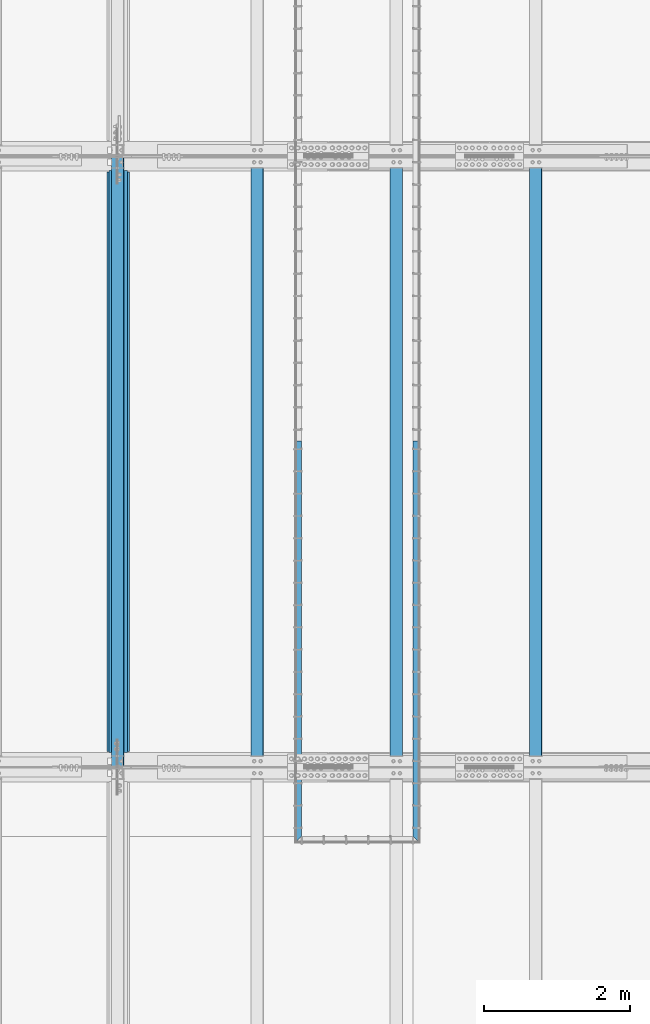
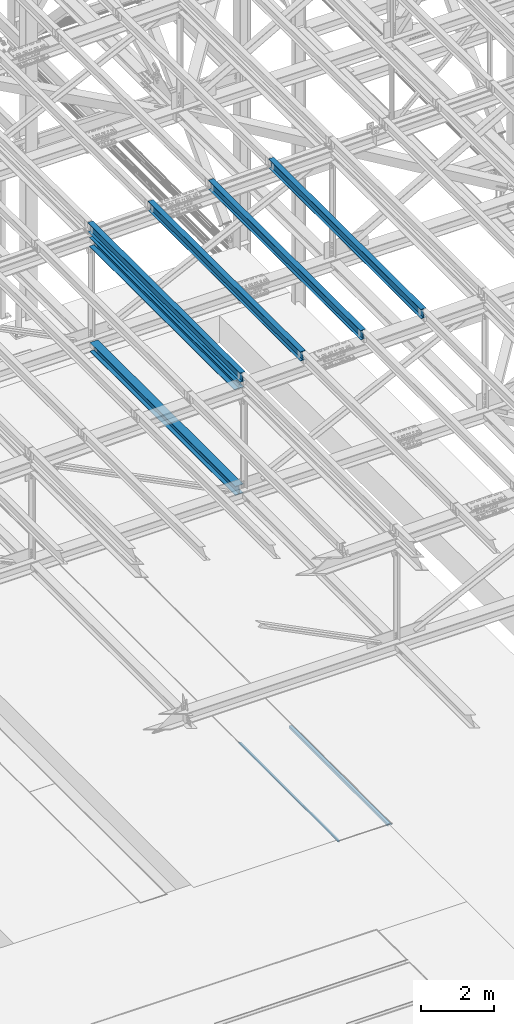
# One storey, part 1899 of 3843: 8 beams, 8 elements without a shape of their own.
"""IFC2X3 building model written with IfcOpenShell, lengths in millimetres."""

from ifc_helpers import new_model, si_unit, frame, origin_with_axes, place, context, subcontext, project, spatial, faceted_brep, material, type_object, element, aggregate, save


model = new_model("IFC2X3")

# Units and contexts
model_context = context("Model", 3, precision=1e-05, world=origin_with_axes())
body_context = subcontext(model_context, "Body", "Model", "MODEL_VIEW")
ifc_project = project(units=[si_unit("LENGTHUNIT", "METRE", prefix="MILLI"), si_unit("AREAUNIT", "SQUARE_METRE"), si_unit("VOLUMEUNIT", "CUBIC_METRE"), si_unit("MASSUNIT", "GRAM", prefix="KILO"), si_unit("TIMEUNIT", "SECOND"), si_unit("PLANEANGLEUNIT", "RADIAN"), si_unit("SOLIDANGLEUNIT", "STERADIAN"), si_unit("THERMODYNAMICTEMPERATUREUNIT", "DEGREE_CELSIUS"), si_unit("LUMINOUSINTENSITYUNIT", "LUMEN")], contexts=[model_context])

# Site, building, storey
site_placement = place(None, origin_with_axes())
site = spatial("IfcSite", under=ifc_project, at=site_placement, CompositionType="ELEMENT")
building_placement = place(site_placement, origin_with_axes())
building = spatial("IfcBuilding", under=site, at=building_placement, Name="Undefined", CompositionType="ELEMENT")
storey_placement = place(building_placement, origin_with_axes())
storey = spatial("IfcBuildingStorey", under=building, at=storey_placement, Name="Undefined", CompositionType="ELEMENT", Elevation=0.0)

# Assembly, beam
assembly_1_placement = place(storey_placement, origin_with_axes())
assembly_1 = element("IfcElementAssembly", 1, at=assembly_1_placement, inside=storey, Name="EMBED_ANGLE", AssemblyPlace="NOTDEFINED", PredefinedType="RIGID_FRAME")
ifc_material_1 = material(Name="STEEL/A36")
beam_type_1 = type_object("IfcBeamType", Name="L3-1/2X3-1/2X5/16", PredefinedType="NOTDEFINED")
beam_1_placement = place(assembly_1_placement, frame((66713.862, 71735.8227029324, 30410.15), z_axis=(0.0, 0.0, -1.0), x_axis=(0.0, -1.0, 0.0)))
beam_1 = element("IfcBeam", 2, at=beam_1_placement, type_object=beam_type_1, material=ifc_material_1, Name="EMBED_ANGLE", ObjectType="L3-1/2X3-1/2X5/16", context=body_context, shape_type="Brep", body=[
    faceted_brep([(-3.63797880709171e-12, 44.4499999999971, -44.4500000000007), (-3.63797880709171e-12, 44.4499999999971, 44.4500000000007), (5409.94572406872, 44.4500000096014, 44.4500000000007), (5409.94572406872, 44.4500000096014, -44.4500000000007), (-3.63797880709171e-12, 36.5124999999971, 44.4500000000007), (5417.88322413992, 36.5125000096305, 44.4500000000007), (-3.63797880709171e-12, 36.5124999999971, -36.5125000000007), (5417.88322413992, 36.5125000096305, -36.5125000000007), (3.63797880709171e-12, -44.4499999999971, -36.5125000000007), (5498.84572486606, -44.4499999902328, -36.5125000000007), (3.63797880709171e-12, -44.4499999999971, -44.4500000000007), (5498.84572486606, -44.4499999902328, -44.4500000000007)], [[[0, 1, 2, 3]], [[1, 4, 5, 2]], [[4, 6, 7, 5]], [[6, 8, 9, 7]], [[8, 10, 11, 9]], [[10, 0, 3, 11]], [[5, 7, 9, 11, 3, 2]], [[10, 8, 6, 4, 1, 0]]]),
])
aggregate(assembly_1, [beam_1])

assembly_2_placement = place(storey_placement, origin_with_axes())
assembly_2 = element("IfcElementAssembly", 3, at=assembly_2_placement, inside=storey, Name="EMBED_ANGLE", AssemblyPlace="NOTDEFINED", PredefinedType="RIGID_FRAME")
beam_2_placement = place(assembly_2_placement, frame((65101.0255318387, 66236.9770354062, 30410.15), z_axis=(0.0, 0.0, -1.0), x_axis=(0.0, 1.0, 0.0)))
beam_2 = element("IfcBeam", 4, at=beam_2_placement, type_object=beam_type_1, material=ifc_material_1, Name="EMBED_ANGLE", ObjectType="L3-1/2X3-1/2X5/16", context=body_context, shape_type="Brep", body=[
    faceted_brep([(88.8999999971129, 44.4500000000007, -44.4499999999971), (88.8999999965163, 44.4499999999971, 44.4500000000007), (5498.84566791133, 44.450000009776, 44.4500000000007), (5498.84566791133, 44.450000009776, -44.4500000000007), (80.9624999965163, 36.5124999999971, 44.4500000000007), (5498.84566791134, 36.512500009776, 44.4500000000007), (80.9624999971129, 36.5125000000007, -36.5124999999971), (5498.84566791134, 36.512500009776, -36.5125000000007), (3.63797880709171e-12, -44.4499999999971, -36.5125000000007), (5498.84566791149, -44.4499999902255, -36.5125000000007), (3.63797880709171e-12, -44.4499999999971, -44.4500000000007), (5498.84566791149, -44.4499999902255, -44.4500000000007)], [[[0, 1, 2, 3]], [[1, 4, 5, 2]], [[4, 6, 7, 5]], [[6, 8, 9, 7]], [[8, 10, 11, 9]], [[10, 0, 3, 11]], [[5, 7, 9, 11, 3, 2]], [[10, 8, 6, 4, 1, 0]]]),
])
aggregate(assembly_2, [beam_2])

assembly_3_placement = place(storey_placement, origin_with_axes())
assembly_3 = element("IfcElementAssembly", 5, at=assembly_3_placement, inside=storey, Name="BEAM", AssemblyPlace="NOTDEFINED", PredefinedType="RIGID_FRAME")
ifc_material_2 = material(Name="STEEL/A992")
beam_type_2 = type_object("IfcBeamType", Name="W12X26", PredefinedType="NOTDEFINED")
beam_3_placement = place(assembly_3_placement, frame((62633.1092623556, 67272.191026649, 46219.7494043175), z_axis=(-0.0211520980329588, 0.00187065200053622, 0.999774519284172), x_axis=(0.0, 0.999998249546997, -0.00187106999915266)))
beam_3 = element("IfcBeam", 6, at=beam_3_placement, type_object=beam_type_2, material=ifc_material_2, Name="BEAM", ObjectType="W12X26", context=body_context, shape_type="Brep", body=[
    faceted_brep([(12.7032892629941, 82.5499999995154, -155.575000000528), (12.6854712773056, 82.54999999953, -146.050000000505), (8343.90005472896, 82.5500000000902, -146.050000027339), (8343.91787271465, 82.5500000000757, -155.575000027362), (12.682329843461, 3.17499999966094, -146.050000000447), (8343.89691329512, 3.17500000022847, -146.05000002728), (12.1359116159729, 3.17500000032305, 146.050000000367), (8343.35049506764, 3.1750000008833, 146.049999973526), (12.1390530498174, 82.5500000001848, 146.050000000309), (8343.35363650149, 82.5500000007451, 146.049999973475), (12.1212350641435, 82.5500000002066, 155.575000000339), (8343.33581851581, 82.5500000007669, 155.574999973498), (12.1147008817643, -82.5499999995227, 155.575000000463), (8343.32928433343, -82.5499999989624, 155.574999973622), (12.1325188674382, -82.5499999995445, 146.050000000432), (8343.34710231911, -82.549999998977, 146.049999973591), (12.1356603012682, -3.17499999967549, 146.050000000374), (8343.35024375295, -3.17499999910797, 146.049999973533), (12.6820785287564, -3.17500000033033, -146.050000000439), (8343.89666198043, -3.1749999997628, -146.05000002728), (12.6789370949264, -82.5500000001921, -146.050000000381), (8343.89352054658, -82.5499999996246, -146.050000027215), (12.6967550806003, -82.5500000002212, -155.575000000412), (8343.91133853226, -82.5499999996537, -155.575000027253)], [[[0, 1, 2, 3]], [[1, 4, 5, 2]], [[4, 6, 7, 5]], [[6, 8, 9, 7]], [[8, 10, 11, 9]], [[10, 12, 13, 11]], [[12, 14, 15, 13]], [[14, 16, 17, 15]], [[16, 18, 19, 17]], [[18, 20, 21, 19]], [[20, 22, 23, 21]], [[22, 0, 3, 23]], [[5, 7, 9, 11, 13, 15, 17, 19, 21, 23, 3, 2]], [[22, 20, 18, 16, 14, 12, 10, 8, 6, 4, 1, 0]]]),
])
aggregate(assembly_3, [beam_3])

assembly_4_placement = place(storey_placement, origin_with_axes())
assembly_4 = element("IfcElementAssembly", 7, at=assembly_4_placement, inside=storey, Name="BEAM", AssemblyPlace="NOTDEFINED", PredefinedType="RIGID_FRAME")
beam_4_placement = place(assembly_4_placement, frame((68348.1094462032, 67272.2190600958, 46344.0829586931), z_axis=(-0.0211520984965173, 0.00205084399976477, 0.999774165883517), x_axis=(5.99999943405563e-09, 0.999997896075788, -0.00205130300015567)))
beam_4 = element("IfcBeam", 8, at=beam_4_placement, type_object=beam_type_2, material=ifc_material_2, Name="BEAM", ObjectType="W12X26", context=body_context, shape_type="Brep", body=[
    faceted_brep([(12.7035580519441, 82.5500000011525, -155.575000000295), (12.6840736823942, 82.5500000011089, -146.05000000033), (8343.90160182866, 82.5500000400352, -146.050000024152), (8343.92113616076, 82.5500000400643, -155.575000024161), (12.6806301202596, 3.17500000065775, -146.050000000265), (8343.89815826656, 3.17500003958412, -146.050000024086), (12.0815772699571, 3.17499999947904, 146.050000000192), (8343.29910541624, 3.17500003841997, 146.049999976378), (12.0850208320917, 82.5499999999156, 146.050000000134), (8343.30254897836, 82.550000038842, 146.049999976312), (12.0654865000106, 82.5499999998865, 155.57500000015), (8343.28301464629, 82.5500000388129, 155.574999976328), (12.0583238907857, -82.5500000010361, 155.575000000281), (8343.27585203706, -82.5499999620952, 155.574999976459), (12.0778582228522, -82.5500000009779, 146.050000000265), (8343.29538636912, -82.5499999620515, 146.049999976443), (12.0813017849869, -3.17500000055588, 146.050000000192), (8343.29882993127, -3.17499996161496, 146.049999976385), (12.6803546352894, -3.17499999936263, -146.050000000265), (8343.89788278157, -3.17499996043625, -146.050000024079), (12.6769110731548, -82.5499999997992, -146.050000000199), (8343.89439661533, -82.5500000213942, -146.050000007497), (12.6964939507743, -82.5499999997555, -155.575000000295), (8343.91397355153, -82.5499999608437, -155.57500002403)], [[[0, 1, 2, 3]], [[1, 4, 5, 2]], [[4, 6, 7, 5]], [[6, 8, 9, 7]], [[8, 10, 11, 9]], [[10, 12, 13, 11]], [[12, 14, 15, 13]], [[14, 16, 17, 15]], [[16, 18, 19, 17]], [[18, 20, 21, 19]], [[20, 22, 23, 21]], [[22, 0, 3, 23]], [[5, 7, 9, 11, 13, 15, 17, 19, 21, 23, 3, 2]], [[22, 20, 18, 16, 14, 12, 10, 8, 6, 4, 1, 0]]]),
])
aggregate(assembly_4, [beam_4])

assembly_5_placement = place(storey_placement, origin_with_axes())
assembly_5 = element("IfcElementAssembly", 9, at=assembly_5_placement, inside=storey, Name="BEAM", AssemblyPlace="NOTDEFINED", PredefinedType="RIGID_FRAME")
beam_5_placement = place(assembly_5_placement, frame((66443.1094461417, 67272.2127350662, 46303.3337451084), z_axis=(-0.0211520978066692, 0.00201018800094608, 0.999774248469412), x_axis=(-2.19999991617404e-08, 0.999997978663364, -0.00201063899932354)))
beam_5 = element("IfcBeam", 10, at=beam_5_placement, type_object=beam_type_2, material=ifc_material_2, Name="BEAM", ObjectType="W12X26", context=body_context, shape_type="Brep", body=[
    faceted_brep([(12.7035580519441, 82.5500000011525, -155.575000000295), (12.6843912363547, 82.5500000007014, -146.049999999967), (8343.90123147771, 82.5500000216707, -146.05000000693), (8343.92037856374, 82.5500000216853, -155.575000006917), (12.681013725407, 3.17500000026484, -146.049999999894), (8343.89785396679, 3.17500002120505, -146.050000006857), (12.0938364208851, 3.17499999982829, 146.049999999865), (8343.31067666227, 3.17500002078305, 146.049999992902), (12.0972139318037, 82.5500000002794, 146.049999999792), (8343.31405417318, 82.5500000212196, 146.049999992829), (12.0780668457883, 82.5500000002503, 155.574999999786), (8343.29490708717, 82.5500000212196, 155.574999992823), (12.0710416230722, -82.5500000006869, 155.574999999939), (8343.28788186445, -82.5499999797321, 155.574999992976), (12.0901887090877, -82.5500000006723, 146.049999999945), (8343.30702895047, -82.5499999797175, 146.049999992982), (12.0935662200063, -3.17500000022119, 146.049999999865), (8343.3104064614, -3.17499997926643, 146.049999992909), (12.6807435245428, -3.17499999978463, -146.049999999886), (8343.89758376591, -3.17499997882987, -146.050000006857), (12.6773660136241, -82.5500000002357, -146.049999999821), (8343.89425563636, -82.5500000219035, -146.049999971714), (12.6964939507743, -82.5499999997555, -155.575000000295), (8343.91335334101, -82.5499999792519, -155.575000006764)], [[[0, 1, 2, 3]], [[1, 4, 5, 2]], [[4, 6, 7, 5]], [[6, 8, 9, 7]], [[8, 10, 11, 9]], [[10, 12, 13, 11]], [[12, 14, 15, 13]], [[14, 16, 17, 15]], [[16, 18, 19, 17]], [[18, 20, 21, 19]], [[20, 22, 23, 21]], [[22, 0, 3, 23]], [[5, 7, 9, 11, 13, 15, 17, 19, 21, 23, 3, 2]], [[22, 20, 18, 16, 14, 12, 10, 8, 6, 4, 1, 0]]]),
])
aggregate(assembly_5, [beam_5])

assembly_6_placement = place(storey_placement, origin_with_axes())
assembly_6 = element("IfcElementAssembly", 11, at=assembly_6_placement, inside=storey, Name="BEAM", AssemblyPlace="NOTDEFINED", PredefinedType="RIGID_FRAME")
beam_6_placement = place(assembly_6_placement, frame((64538.1094461227, 67272.2018182341, 46261.8927532986), z_axis=(-0.0211520978190965, 0.00194001800016849, 0.999774387093413), x_axis=(5.99999989092142e-09, 0.999998117321244, -0.00194045200062302)))
beam_6 = element("IfcBeam", 12, at=beam_6_placement, type_object=beam_type_2, material=ifc_material_2, Name="BEAM", ObjectType="W12X26", context=body_context, shape_type="Brep", body=[
    faceted_brep([(12.7033947434393, 82.5499999995664, -155.574999999517), (12.6849330138648, 82.549999999952, -146.050000000578), (8343.90061794361, 82.5499999774693, -146.049999987285), (8343.91909664973, 82.5499999774693, -155.574999987301), (12.6816755661275, 3.17500000009022, -146.050000000316), (8343.89736049587, 3.17499997759296, -146.049999987015), (12.114995244905, 3.17499999982829, 146.050000000323), (8343.33068017464, 3.1749999773383, 146.050000013609), (12.1182526926423, 82.54999999969, 146.050000000054), (8343.33393762239, 82.5499999772073, 146.050000013347), (12.099773986527, 82.5499999996828, 155.575000000077), (8343.31545891627, 82.5499999772001, 155.575000013363), (12.0929984952236, -82.5500000000393, 155.57500000063), (8343.30868342496, -82.550000022522, 155.575000013923), (12.1114772013534, -82.5500000000247, 146.050000000614), (8343.3271621311, -82.550000022522, 146.050000013907), (12.1147346490907, -3.17500000016298, 146.050000000345), (8343.33041957882, -3.17500002265297, 146.050000013631), (12.6814149702986, -3.17499999990832, -146.050000000287), (8343.89709990004, -3.17500002239103, -146.049999986993), (12.6781575225905, -82.5499999997774, -146.050000000017), (8343.89384245234, -82.5500000222601, -146.049999986732), (12.6966526176693, -82.5500000013417, -155.575000000026), (8343.91232115845, -82.5500000222455, -155.574999986748)], [[[0, 1, 2, 3]], [[1, 4, 5, 2]], [[4, 6, 7, 5]], [[6, 8, 9, 7]], [[8, 10, 11, 9]], [[10, 12, 13, 11]], [[12, 14, 15, 13]], [[14, 16, 17, 15]], [[16, 18, 19, 17]], [[18, 20, 21, 19]], [[20, 22, 23, 21]], [[22, 0, 3, 23]], [[5, 7, 9, 11, 13, 15, 17, 19, 21, 23, 3, 2]], [[22, 20, 18, 16, 14, 12, 10, 8, 6, 4, 1, 0]]]),
])
aggregate(assembly_6, [beam_6])

assembly_7_placement = place(storey_placement, origin_with_axes())
assembly_7 = element("IfcElementAssembly", 13, at=assembly_7_placement, inside=storey, Name="BEAM", AssemblyPlace="NOTDEFINED", PredefinedType="RIGID_FRAME")
beam_type_3 = type_object("IfcBeamType", Name="W12X65", PredefinedType="NOTDEFINED")
beam_7_placement = place(assembly_7_placement, frame((62636.4, 67271.8999999996, 45867.3116480938), z_axis=(0.0, 0.00187106999914977, 0.999998249546997), x_axis=(0.0, 0.999998249546997, -0.00187106999915266)))
beam_7 = element("IfcBeam", 14, at=beam_7_placement, type_object=beam_type_3, material=ifc_material_2, Name="BEAM", ObjectType="W12X65", context=body_context, shape_type="Brep", body=[
    faceted_brep([(213.01349426448, 152.400000000001, -153.98750000116), (212.983790976126, 152.400000000001, -138.112500001109), (8144.14767415529, 152.400000000001, -138.112500026662), (8144.17737744363, 152.400000000001, -153.987500026713), (212.983790976126, 4.76249999999709, -138.112500001109), (8144.14767415529, 4.76249999999709, -138.112500026662), (212.466953758892, 4.76249999999709, 138.112499999748), (8143.63083693807, 4.76249999999709, 138.112499974202), (212.466953758892, 152.400000000001, 138.112499999748), (8143.63083693807, 152.400000000001, 138.112499974202), (212.437250470539, 152.400000000001, 153.987499999799), (8143.60113364973, 152.400000000001, 153.987499974246), (212.437250470539, -152.400000000001, 153.987499999799), (8143.60113364973, -152.400000000001, 153.987499974246), (212.466953758892, -152.400000000001, 138.112499999748), (8143.63083693807, -152.400000000001, 138.112499974202), (212.466953758892, -4.76249999999709, 138.112499999748), (8143.63083693807, -4.76249999999709, 138.112499974202), (212.983790976126, -4.76249999999709, -138.112500001109), (8144.14767415529, -4.76249999999709, -138.112500026662), (212.983790976126, -152.400000000001, -138.112500001109), (8144.14767415529, -152.400000000001, -138.112500026662), (213.01349426448, -152.400000000001, -153.98750000116), (8144.17737744363, -152.400000000001, -153.987500026713)], [[[0, 1, 2, 3]], [[1, 4, 5, 2]], [[4, 6, 7, 5]], [[6, 8, 9, 7]], [[8, 10, 11, 9]], [[10, 12, 13, 11]], [[12, 14, 15, 13]], [[14, 16, 17, 15]], [[16, 18, 19, 17]], [[18, 20, 21, 19]], [[20, 22, 23, 21]], [[22, 0, 3, 23]], [[5, 7, 9, 11, 13, 15, 17, 19, 21, 23, 3, 2]], [[22, 20, 18, 16, 14, 12, 10, 8, 6, 4, 1, 0]]]),
])
aggregate(assembly_7, [beam_7])

assembly_8_placement = place(storey_placement, origin_with_axes())
assembly_8 = element("IfcElementAssembly", 15, at=assembly_8_placement, inside=storey, Name="BEAM", AssemblyPlace="NOTDEFINED", PredefinedType="RIGID_FRAME")
beam_type_4 = type_object("IfcBeamType", Name="W12X53", PredefinedType="NOTDEFINED")
beam_8_placement = place(assembly_8_placement, frame((62636.4, 67271.9000000011, 42341.0067436681), z_axis=(0.0, 0.00187106999914977, 0.999998249546997), x_axis=(0.0, 0.999998249546997, -0.00187106999915266)))
beam_8 = element("IfcBeam", 16, at=beam_8_placement, type_object=beam_type_4, material=ifc_material_2, Name="BEAM", ObjectType="W12X53", context=body_context, shape_type="Brep", body=[
    faceted_brep([(198.722988684036, 127.0, -152.399999999965), (198.696256681898, 127.0, -138.112499999945), (8158.43518874023, 127.0, -138.112499989686), (8158.46192074237, 127.0, -152.399999989699), (198.696256681898, 4.76249999999709, -138.112499999945), (8158.43518874023, 4.76249999999709, -138.112499989686), (198.179437973784, 4.76249999999709, 138.112500000454), (8157.91837003214, 4.76249999999709, 138.11250001072), (198.179437973784, 127.0, 138.112500000454), (8157.91837003214, 127.0, 138.11250001072), (198.152705971646, 127.0, 152.400000000474), (8157.89163802999, 127.0, 152.400000010741), (198.152705971646, -127.0, 152.400000000474), (8157.89163802999, -127.0, 152.400000010741), (198.179437973784, -127.0, 138.112500000454), (8157.91837003214, -127.0, 138.11250001072), (198.179437973784, -4.76249999999709, 138.112500000454), (8157.91837003214, -4.76249999999709, 138.11250001072), (198.696256681898, -4.76249999999709, -138.112499999945), (8158.43518874023, -4.76249999999709, -138.112499989686), (198.696256681898, -127.0, -138.112499999945), (8158.43518874023, -127.0, -138.112499989686), (198.722988684036, -127.0, -152.399999999965), (8158.46192074237, -127.0, -152.399999989699)], [[[0, 1, 2, 3]], [[1, 4, 5, 2]], [[4, 6, 7, 5]], [[6, 8, 9, 7]], [[8, 10, 11, 9]], [[10, 12, 13, 11]], [[12, 14, 15, 13]], [[14, 16, 17, 15]], [[16, 18, 19, 17]], [[18, 20, 21, 19]], [[20, 22, 23, 21]], [[22, 0, 3, 23]], [[5, 7, 9, 11, 13, 15, 17, 19, 21, 23, 3, 2]], [[22, 20, 18, 16, 14, 12, 10, 8, 6, 4, 1, 0]]]),
])
aggregate(assembly_8, [beam_8])

save(model, "model.ifc")
